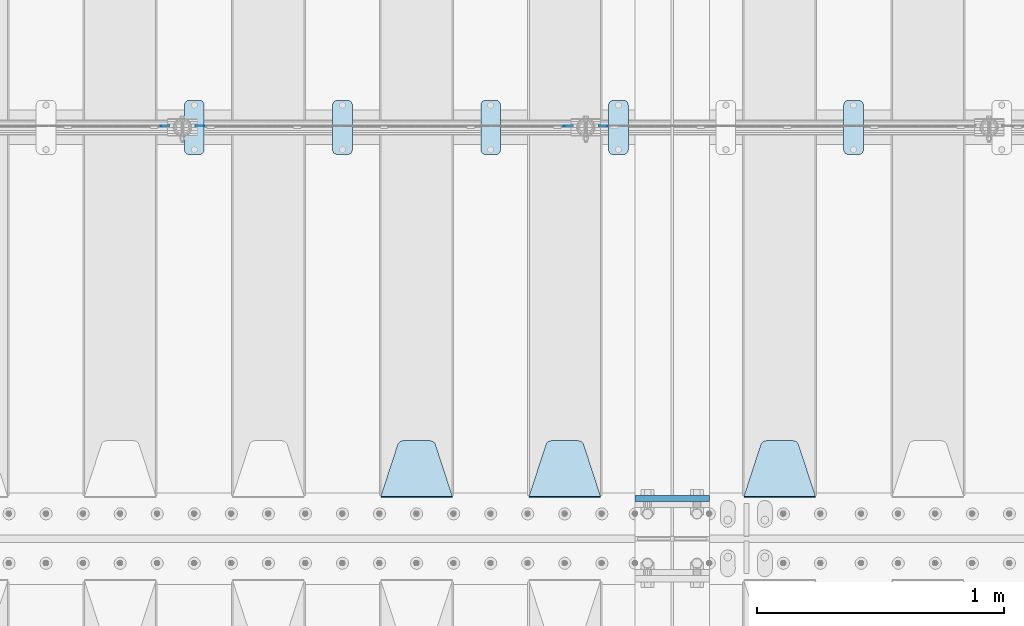
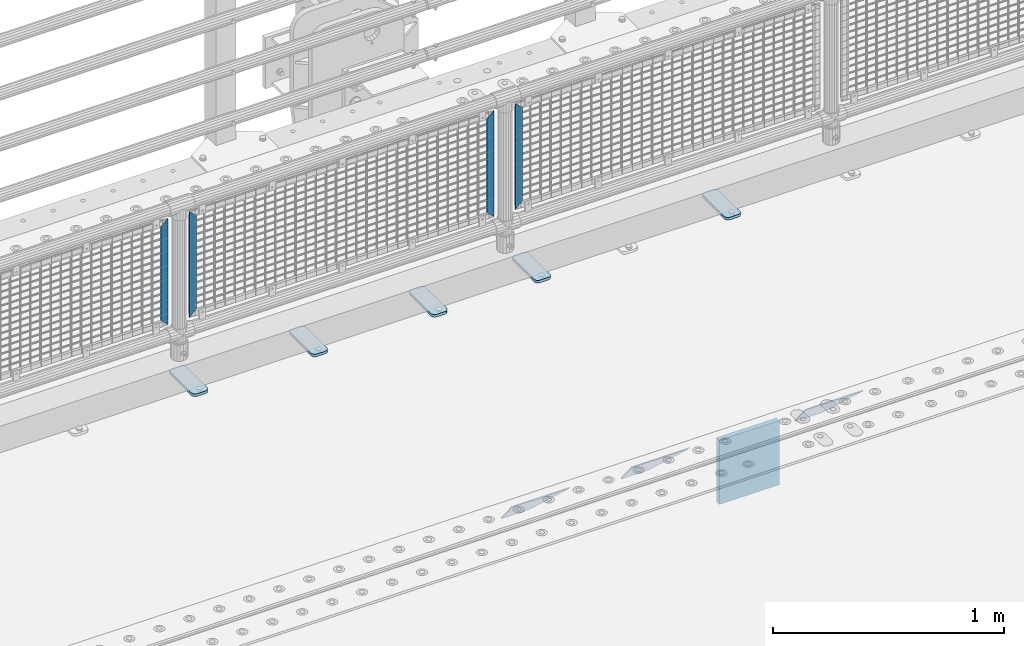
# One storey, part 214 of 242: 13 plates.
"""IFC2X3 building model written with IfcOpenShell, lengths in millimetres."""

from ifc_helpers import new_model, si_unit, frame, origin_with_axes, place, context, subcontext, project, spatial, faceted_brep, material, type_object, element, save


model = new_model("IFC2X3")

# Units and contexts
model_context = context("Model", 3, precision=1e-05, world=origin_with_axes())
body_context = subcontext(model_context, "Body", "Model", "MODEL_VIEW")
ifc_project = project(units=[si_unit("LENGTHUNIT", "METRE", prefix="MILLI"), si_unit("AREAUNIT", "SQUARE_METRE"), si_unit("VOLUMEUNIT", "CUBIC_METRE"), si_unit("MASSUNIT", "GRAM", prefix="KILO"), si_unit("TIMEUNIT", "SECOND"), si_unit("PLANEANGLEUNIT", "RADIAN"), si_unit("SOLIDANGLEUNIT", "STERADIAN"), si_unit("THERMODYNAMICTEMPERATUREUNIT", "DEGREE_CELSIUS"), si_unit("LUMINOUSINTENSITYUNIT", "LUMEN")], contexts=[model_context])

# Site, building, storey
site_placement = place(None, origin_with_axes())
site = spatial("IfcSite", under=ifc_project, at=site_placement, CompositionType="ELEMENT")
building_placement = place(site_placement, origin_with_axes())
building = spatial("IfcBuilding", under=site, at=building_placement, Name="Standard", CompositionType="ELEMENT")
storey_placement = place(building_placement, origin_with_axes())
storey = spatial("IfcBuildingStorey", under=building, at=storey_placement, Name="Undefined", CompositionType="ELEMENT", Elevation=0.0)

# Plates
ifc_material_1 = material(Name="Misc_Undefined")
plate_type_1 = type_object("IfcPlateType", PredefinedType="NOTDEFINED")
for number, where, z_axis, x_axis in (
    (1, (-28676.490286459, -19329.5, 879.519963133601), (-0.707008801899319, 0.0, -0.707204746899291), (-0.707204746899296, 0.0, 0.707008801899313)),
    (2, (-30309.490286459, -19329.5, 879.519963133601), (-0.707008801899319, 0.0, -0.707204746899291), (-0.707204746899296, 0.0, 0.707008801899313)),
):
    element("IfcPlate", number, at=place(storey_placement, frame(where, z_axis=z_axis, x_axis=x_axis)), inside=storey, type_object=plate_type_1, material=ifc_material_1, context=body_context, shape_type="Brep", body=[
        faceted_brep([(0.0, -1.50000000000364, 0.0), (-348.552185058597, -1.5, 348.655029296875), (-348.552185058597, 1.5, 348.655029296875), (-3.63797880709171e-12, 1.49999999999636, 0.0), (-348.544891357426, -1.5, 398.152496337891), (-348.544891357426, 1.5, 398.152496337891), (49.5043945312464, -1.5, 8.00355337560177e-11), (49.5043945312464, 1.5, 8.00355337560177e-11)], [[[0, 1, 2, 3]], [[1, 4, 5, 2]], [[4, 6, 7, 5]], [[6, 0, 3, 7]], [[5, 7, 3, 2]], [[6, 4, 1, 0]]]),
    ])
for number, where, z_axis, x_axis in (
    (3, (-28853.5003125164, -19329.5, 879.52), (0.707103624179499, 0.0, -0.707109938179501), (0.707109938179508, 0.0, 0.707103624179492)),
    (4, (-30486.5003125164, -19329.5, 879.52), (0.707103624179499, 0.0, -0.707109938179501), (0.707109938179508, 0.0, 0.707103624179492)),
):
    element("IfcPlate", number, at=place(storey_placement, frame(where, z_axis=z_axis, x_axis=x_axis)), inside=storey, type_object=plate_type_1, material=ifc_material_1, context=body_context, shape_type="Brep", body=[
        faceted_brep([(0.0, -1.50000000000364, 0.0), (-348.605163574222, -1.5, 348.602081298832), (-348.605163574222, 1.5, 348.602081298832), (-3.63797880709171e-12, 1.49999999999636, 0.0), (-348.605163574222, -1.5, 398.099334716801), (-348.605163574222, 1.5, 398.099334716801), (49.4976959228534, -1.5, -3.63797880709171e-12), (49.4976959228534, 1.5, -3.63797880709171e-12)], [[[0, 1, 2, 3]], [[1, 4, 5, 2]], [[4, 6, 7, 5]], [[6, 0, 3, 7]], [[5, 7, 3, 2]], [[6, 4, 1, 0]]]),
    ])
ifc_material_2 = material(Name="STEEL/S355J2")
plate_type_2 = type_object("IfcPlateType", PredefinedType="NOTDEFINED")
plate_1_placement = place(storey_placement, frame((-27721.0, -19225.5, 21.0199999999977), z_axis=(1.0, 0.0, 0.0), x_axis=(0.0, -1.0, 0.0)))
element("IfcPlate", 5, at=plate_1_placement, inside=storey, type_object=plate_type_2, material=ifc_material_2, context=body_context, shape_type="Brep", body=[
    faceted_brep([(0.0, -7.0, 20.0), (0.0, -7.0, 60.0), (0.0, 7.0, 60.0), (0.0, 7.0, 20.0), (0.384294391937146, -7.0, 63.9018064403208), (0.384294391937146, 7.0, 63.9018064403208), (1.52240934977453, -7.0, 67.6536686473009), (1.52240934977453, 7.0, 67.6536686473009), (3.37060775395003, -7.0, 71.1114046603907), (3.37060775395003, 7.0, 71.1114046603907), (5.8578643762703, -7.0, 74.1421356237297), (5.8578643762703, 7.0, 74.1421356237297), (8.88859533960931, -7.0, 76.62939224605), (8.88859533960931, 7.0, 76.62939224605), (12.3463313526991, -7.0, 78.4775906502255), (12.3463313526991, 7.0, 78.4775906502255), (16.0981935596792, -7.0, 79.6157056080629), (16.0981935596792, 7.0, 79.6157056080629), (20.0, -7.0, 80.0), (20.0, 7.0, 80.0), (200.0, -7.0, 80.0), (200.0, 7.0, 80.0), (203.901806440321, -7.0, 79.6157056080629), (203.901806440321, 7.0, 79.6157056080629), (207.653668647301, -7.0, 78.4775906502255), (207.653668647301, 7.0, 78.4775906502255), (211.111404660391, -7.0, 76.62939224605), (211.111404660391, 7.0, 76.62939224605), (214.14213562373, -7.0, 74.1421356237297), (214.14213562373, 7.0, 74.1421356237297), (216.62939224605, -7.0, 71.1114046603907), (216.62939224605, 7.0, 71.1114046603907), (218.477590650225, -7.0, 67.6536686473009), (218.477590650225, 7.0, 67.6536686473009), (219.615705608063, -7.0, 63.9018064403208), (219.615705608063, 7.0, 63.9018064403208), (220.0, -7.0, 60.0), (220.0, 7.0, 60.0), (220.0, -7.0, 20.0), (220.0, 7.0, 20.0), (219.615705608063, -7.0, 16.0981935596792), (219.615705608063, 7.0, 16.0981935596792), (218.477590650225, -7.0, 12.3463313526991), (218.477590650225, 7.0, 12.3463313526991), (216.62939224605, -7.0, 8.88859533960931), (216.62939224605, 7.0, 8.88859533960931), (214.14213562373, -7.0, 5.8578643762703), (214.14213562373, 7.0, 5.8578643762703), (211.111404660391, -7.0, 3.37060775395003), (211.111404660391, 7.0, 3.37060775395003), (207.653668647301, -7.0, 1.52240934977453), (207.653668647301, 7.0, 1.52240934977453), (203.901806440321, -7.0, 0.384294391937146), (203.901806440321, 7.0, 0.384294391937146), (200.0, -7.0, 0.0), (200.0, 7.0, 0.0), (20.0, -7.0, 0.0), (20.0, 7.0, 0.0), (16.0981935596792, -7.0, 0.384294391937146), (16.0981935596792, 7.0, 0.384294391937146), (12.3463313526991, -7.0, 1.52240934977453), (12.3463313526991, 7.0, 1.52240934977453), (8.88859533960931, -7.0, 3.37060775395003), (8.88859533960931, 7.0, 3.37060775395003), (5.8578643762703, -7.0, 5.8578643762703), (5.8578643762703, 7.0, 5.8578643762703), (3.37060775395003, -7.0, 8.88859533960931), (3.37060775395003, 7.0, 8.88859533960931), (1.52240934977453, -7.0, 12.3463313526991), (1.52240934977453, 7.0, 12.3463313526991), (0.384294391937146, -7.0, 16.0981935596792), (0.384294391937146, 7.0, 16.0981935596792)], [[[0, 1, 2, 3]], [[1, 4, 5, 2]], [[4, 6, 7, 5]], [[6, 8, 9, 7]], [[8, 10, 11, 9]], [[10, 12, 13, 11]], [[12, 14, 15, 13]], [[14, 16, 17, 15]], [[16, 18, 19, 17]], [[18, 20, 21, 19]], [[20, 22, 23, 21]], [[22, 24, 25, 23]], [[24, 26, 27, 25]], [[26, 28, 29, 27]], [[28, 30, 31, 29]], [[30, 32, 33, 31]], [[32, 34, 35, 33]], [[34, 36, 37, 35]], [[36, 38, 39, 37]], [[38, 40, 41, 39]], [[40, 42, 43, 41]], [[42, 44, 45, 43]], [[44, 46, 47, 45]], [[46, 48, 49, 47]], [[48, 50, 51, 49]], [[50, 52, 53, 51]], [[52, 54, 55, 53]], [[54, 56, 57, 55]], [[56, 58, 59, 57]], [[58, 60, 61, 59]], [[60, 62, 63, 61]], [[62, 64, 65, 63]], [[64, 66, 67, 65]], [[66, 68, 69, 67]], [[68, 70, 71, 69]], [[70, 0, 3, 71]], [[5, 7, 9, 11, 13, 15, 17, 19, 21, 23, 25, 27, 29, 31, 33, 35, 37, 39, 41, 43, 45, 47, 49, 51, 53, 55, 57, 59, 61, 63, 65, 67, 69, 71, 3, 2]], [[70, 68, 66, 64, 62, 60, 58, 56, 54, 52, 50, 48, 46, 44, 42, 40, 38, 36, 34, 32, 30, 28, 26, 24, 22, 20, 18, 16, 14, 12, 10, 8, 6, 4, 1, 0]]]),
])
plate_2_placement = place(storey_placement, frame((-28673.0, -19225.5, 21.0199999999977), z_axis=(1.0, 0.0, 0.0), x_axis=(0.0, -1.0, 0.0)))
element("IfcPlate", 6, at=plate_2_placement, inside=storey, type_object=plate_type_2, material=ifc_material_2, context=body_context, shape_type="Brep", body=[
    faceted_brep([(0.0, -7.0, 20.0), (0.0, -7.0, 60.0), (0.0, 7.0, 60.0), (0.0, 7.0, 20.0), (0.384294391937146, -7.0, 63.9018064403208), (0.384294391937146, 7.0, 63.9018064403208), (1.52240934977453, -7.0, 67.6536686473009), (1.52240934977453, 7.0, 67.6536686473009), (3.37060775395003, -7.0, 71.1114046603907), (3.37060775395003, 7.0, 71.1114046603907), (5.8578643762703, -7.0, 74.1421356237297), (5.8578643762703, 7.0, 74.1421356237297), (8.88859533960931, -7.0, 76.62939224605), (8.88859533960931, 7.0, 76.62939224605), (12.3463313526991, -7.0, 78.4775906502255), (12.3463313526991, 7.0, 78.4775906502255), (16.0981935596792, -7.0, 79.6157056080629), (16.0981935596792, 7.0, 79.6157056080629), (20.0, -7.0, 80.0), (20.0, 7.0, 80.0), (200.0, -7.0, 80.0), (200.0, 7.0, 80.0), (203.901806440321, -7.0, 79.6157056080629), (203.901806440321, 7.0, 79.6157056080629), (207.653668647301, -7.0, 78.4775906502255), (207.653668647301, 7.0, 78.4775906502255), (211.111404660391, -7.0, 76.62939224605), (211.111404660391, 7.0, 76.62939224605), (214.14213562373, -7.0, 74.1421356237297), (214.14213562373, 7.0, 74.1421356237297), (216.62939224605, -7.0, 71.1114046603907), (216.62939224605, 7.0, 71.1114046603907), (218.477590650225, -7.0, 67.6536686473009), (218.477590650225, 7.0, 67.6536686473009), (219.615705608063, -7.0, 63.9018064403208), (219.615705608063, 7.0, 63.9018064403208), (220.0, -7.0, 60.0), (220.0, 7.0, 60.0), (220.0, -7.0, 20.0), (220.0, 7.0, 20.0), (219.615705608063, -7.0, 16.0981935596792), (219.615705608063, 7.0, 16.0981935596792), (218.477590650225, -7.0, 12.3463313526991), (218.477590650225, 7.0, 12.3463313526991), (216.62939224605, -7.0, 8.88859533960931), (216.62939224605, 7.0, 8.88859533960931), (214.14213562373, -7.0, 5.8578643762703), (214.14213562373, 7.0, 5.8578643762703), (211.111404660391, -7.0, 3.37060775395003), (211.111404660391, 7.0, 3.37060775395003), (207.653668647301, -7.0, 1.52240934977453), (207.653668647301, 7.0, 1.52240934977453), (203.901806440321, -7.0, 0.384294391937146), (203.901806440321, 7.0, 0.384294391937146), (200.0, -7.0, 0.0), (200.0, 7.0, 0.0), (20.0, -7.0, 0.0), (20.0, 7.0, 0.0), (16.0981935596792, -7.0, 0.384294391937146), (16.0981935596792, 7.0, 0.384294391937146), (12.3463313526991, -7.0, 1.52240934977453), (12.3463313526991, 7.0, 1.52240934977453), (8.88859533960931, -7.0, 3.37060775395003), (8.88859533960931, 7.0, 3.37060775395003), (5.8578643762703, -7.0, 5.8578643762703), (5.8578643762703, 7.0, 5.8578643762703), (3.37060775395003, -7.0, 8.88859533960931), (3.37060775395003, 7.0, 8.88859533960931), (1.52240934977453, -7.0, 12.3463313526991), (1.52240934977453, 7.0, 12.3463313526991), (0.384294391937146, -7.0, 16.0981935596792), (0.384294391937146, 7.0, 16.0981935596792)], [[[0, 1, 2, 3]], [[1, 4, 5, 2]], [[4, 6, 7, 5]], [[6, 8, 9, 7]], [[8, 10, 11, 9]], [[10, 12, 13, 11]], [[12, 14, 15, 13]], [[14, 16, 17, 15]], [[16, 18, 19, 17]], [[18, 20, 21, 19]], [[20, 22, 23, 21]], [[22, 24, 25, 23]], [[24, 26, 27, 25]], [[26, 28, 29, 27]], [[28, 30, 31, 29]], [[30, 32, 33, 31]], [[32, 34, 35, 33]], [[34, 36, 37, 35]], [[36, 38, 39, 37]], [[38, 40, 41, 39]], [[40, 42, 43, 41]], [[42, 44, 45, 43]], [[44, 46, 47, 45]], [[46, 48, 49, 47]], [[48, 50, 51, 49]], [[50, 52, 53, 51]], [[52, 54, 55, 53]], [[54, 56, 57, 55]], [[56, 58, 59, 57]], [[58, 60, 61, 59]], [[60, 62, 63, 61]], [[62, 64, 65, 63]], [[64, 66, 67, 65]], [[66, 68, 69, 67]], [[68, 70, 71, 69]], [[70, 0, 3, 71]], [[5, 7, 9, 11, 13, 15, 17, 19, 21, 23, 25, 27, 29, 31, 33, 35, 37, 39, 41, 43, 45, 47, 49, 51, 53, 55, 57, 59, 61, 63, 65, 67, 69, 71, 3, 2]], [[70, 68, 66, 64, 62, 60, 58, 56, 54, 52, 50, 48, 46, 44, 42, 40, 38, 36, 34, 32, 30, 28, 26, 24, 22, 20, 18, 16, 14, 12, 10, 8, 6, 4, 1, 0]]]),
])
plate_3_placement = place(storey_placement, frame((-29190.0, -19225.5, 21.0199999999977), z_axis=(1.0, 0.0, 0.0), x_axis=(0.0, -1.0, 0.0)))
element("IfcPlate", 7, at=plate_3_placement, inside=storey, type_object=plate_type_2, material=ifc_material_2, context=body_context, shape_type="Brep", body=[
    faceted_brep([(0.0, -7.0, 20.0), (0.0, -7.0, 60.0), (0.0, 7.0, 60.0), (0.0, 7.0, 20.0), (0.384294391937146, -7.0, 63.9018064403208), (0.384294391937146, 7.0, 63.9018064403208), (1.52240934977453, -7.0, 67.6536686473009), (1.52240934977453, 7.0, 67.6536686473009), (3.37060775395003, -7.0, 71.1114046603907), (3.37060775395003, 7.0, 71.1114046603907), (5.8578643762703, -7.0, 74.1421356237297), (5.8578643762703, 7.0, 74.1421356237297), (8.88859533960931, -7.0, 76.62939224605), (8.88859533960931, 7.0, 76.62939224605), (12.3463313526991, -7.0, 78.4775906502255), (12.3463313526991, 7.0, 78.4775906502255), (16.0981935596792, -7.0, 79.6157056080629), (16.0981935596792, 7.0, 79.6157056080629), (20.0, -7.0, 80.0), (20.0, 7.0, 80.0), (200.0, -7.0, 80.0), (200.0, 7.0, 80.0), (203.901806440321, -7.0, 79.6157056080629), (203.901806440321, 7.0, 79.6157056080629), (207.653668647301, -7.0, 78.4775906502255), (207.653668647301, 7.0, 78.4775906502255), (211.111404660391, -7.0, 76.62939224605), (211.111404660391, 7.0, 76.62939224605), (214.14213562373, -7.0, 74.1421356237297), (214.14213562373, 7.0, 74.1421356237297), (216.62939224605, -7.0, 71.1114046603907), (216.62939224605, 7.0, 71.1114046603907), (218.477590650225, -7.0, 67.6536686473009), (218.477590650225, 7.0, 67.6536686473009), (219.615705608063, -7.0, 63.9018064403208), (219.615705608063, 7.0, 63.9018064403208), (220.0, -7.0, 60.0), (220.0, 7.0, 60.0), (220.0, -7.0, 20.0), (220.0, 7.0, 20.0), (219.615705608063, -7.0, 16.0981935596792), (219.615705608063, 7.0, 16.0981935596792), (218.477590650225, -7.0, 12.3463313526991), (218.477590650225, 7.0, 12.3463313526991), (216.62939224605, -7.0, 8.88859533960931), (216.62939224605, 7.0, 8.88859533960931), (214.14213562373, -7.0, 5.8578643762703), (214.14213562373, 7.0, 5.8578643762703), (211.111404660391, -7.0, 3.37060775395003), (211.111404660391, 7.0, 3.37060775395003), (207.653668647301, -7.0, 1.52240934977453), (207.653668647301, 7.0, 1.52240934977453), (203.901806440321, -7.0, 0.384294391937146), (203.901806440321, 7.0, 0.384294391937146), (200.0, -7.0, 0.0), (200.0, 7.0, 0.0), (20.0, -7.0, 0.0), (20.0, 7.0, 0.0), (16.0981935596792, -7.0, 0.384294391937146), (16.0981935596792, 7.0, 0.384294391937146), (12.3463313526991, -7.0, 1.52240934977453), (12.3463313526991, 7.0, 1.52240934977453), (8.88859533960931, -7.0, 3.37060775395003), (8.88859533960931, 7.0, 3.37060775395003), (5.8578643762703, -7.0, 5.8578643762703), (5.8578643762703, 7.0, 5.8578643762703), (3.37060775395003, -7.0, 8.88859533960931), (3.37060775395003, 7.0, 8.88859533960931), (1.52240934977453, -7.0, 12.3463313526991), (1.52240934977453, 7.0, 12.3463313526991), (0.384294391937146, -7.0, 16.0981935596792), (0.384294391937146, 7.0, 16.0981935596792)], [[[0, 1, 2, 3]], [[1, 4, 5, 2]], [[4, 6, 7, 5]], [[6, 8, 9, 7]], [[8, 10, 11, 9]], [[10, 12, 13, 11]], [[12, 14, 15, 13]], [[14, 16, 17, 15]], [[16, 18, 19, 17]], [[18, 20, 21, 19]], [[20, 22, 23, 21]], [[22, 24, 25, 23]], [[24, 26, 27, 25]], [[26, 28, 29, 27]], [[28, 30, 31, 29]], [[30, 32, 33, 31]], [[32, 34, 35, 33]], [[34, 36, 37, 35]], [[36, 38, 39, 37]], [[38, 40, 41, 39]], [[40, 42, 43, 41]], [[42, 44, 45, 43]], [[44, 46, 47, 45]], [[46, 48, 49, 47]], [[48, 50, 51, 49]], [[50, 52, 53, 51]], [[52, 54, 55, 53]], [[54, 56, 57, 55]], [[56, 58, 59, 57]], [[58, 60, 61, 59]], [[60, 62, 63, 61]], [[62, 64, 65, 63]], [[64, 66, 67, 65]], [[66, 68, 69, 67]], [[68, 70, 71, 69]], [[70, 0, 3, 71]], [[5, 7, 9, 11, 13, 15, 17, 19, 21, 23, 25, 27, 29, 31, 33, 35, 37, 39, 41, 43, 45, 47, 49, 51, 53, 55, 57, 59, 61, 63, 65, 67, 69, 71, 3, 2]], [[70, 68, 66, 64, 62, 60, 58, 56, 54, 52, 50, 48, 46, 44, 42, 40, 38, 36, 34, 32, 30, 28, 26, 24, 22, 20, 18, 16, 14, 12, 10, 8, 6, 4, 1, 0]]]),
])
plate_4_placement = place(storey_placement, frame((-29790.0, -19225.5, 21.0199999999977), z_axis=(1.0, 0.0, 0.0), x_axis=(0.0, -1.0, 0.0)))
element("IfcPlate", 8, at=plate_4_placement, inside=storey, type_object=plate_type_2, material=ifc_material_2, context=body_context, shape_type="Brep", body=[
    faceted_brep([(0.0, -7.0, 20.0), (0.0, -7.0, 60.0), (0.0, 7.0, 60.0), (0.0, 7.0, 20.0), (0.384294391937146, -7.0, 63.9018064403208), (0.384294391937146, 7.0, 63.9018064403208), (1.52240934977453, -7.0, 67.6536686473009), (1.52240934977453, 7.0, 67.6536686473009), (3.37060775395003, -7.0, 71.1114046603907), (3.37060775395003, 7.0, 71.1114046603907), (5.8578643762703, -7.0, 74.1421356237297), (5.8578643762703, 7.0, 74.1421356237297), (8.88859533960931, -7.0, 76.62939224605), (8.88859533960931, 7.0, 76.62939224605), (12.3463313526991, -7.0, 78.4775906502255), (12.3463313526991, 7.0, 78.4775906502255), (16.0981935596792, -7.0, 79.6157056080629), (16.0981935596792, 7.0, 79.6157056080629), (20.0, -7.0, 80.0), (20.0, 7.0, 80.0), (200.0, -7.0, 80.0), (200.0, 7.0, 80.0), (203.901806440321, -7.0, 79.6157056080629), (203.901806440321, 7.0, 79.6157056080629), (207.653668647301, -7.0, 78.4775906502255), (207.653668647301, 7.0, 78.4775906502255), (211.111404660391, -7.0, 76.62939224605), (211.111404660391, 7.0, 76.62939224605), (214.14213562373, -7.0, 74.1421356237297), (214.14213562373, 7.0, 74.1421356237297), (216.62939224605, -7.0, 71.1114046603907), (216.62939224605, 7.0, 71.1114046603907), (218.477590650225, -7.0, 67.6536686473009), (218.477590650225, 7.0, 67.6536686473009), (219.615705608063, -7.0, 63.9018064403208), (219.615705608063, 7.0, 63.9018064403208), (220.0, -7.0, 60.0), (220.0, 7.0, 60.0), (220.0, -7.0, 20.0), (220.0, 7.0, 20.0), (219.615705608063, -7.0, 16.0981935596792), (219.615705608063, 7.0, 16.0981935596792), (218.477590650225, -7.0, 12.3463313526991), (218.477590650225, 7.0, 12.3463313526991), (216.62939224605, -7.0, 8.88859533960931), (216.62939224605, 7.0, 8.88859533960931), (214.14213562373, -7.0, 5.8578643762703), (214.14213562373, 7.0, 5.8578643762703), (211.111404660391, -7.0, 3.37060775395003), (211.111404660391, 7.0, 3.37060775395003), (207.653668647301, -7.0, 1.52240934977453), (207.653668647301, 7.0, 1.52240934977453), (203.901806440321, -7.0, 0.384294391937146), (203.901806440321, 7.0, 0.384294391937146), (200.0, -7.0, 0.0), (200.0, 7.0, 0.0), (20.0, -7.0, 0.0), (20.0, 7.0, 0.0), (16.0981935596792, -7.0, 0.384294391937146), (16.0981935596792, 7.0, 0.384294391937146), (12.3463313526991, -7.0, 1.52240934977453), (12.3463313526991, 7.0, 1.52240934977453), (8.88859533960931, -7.0, 3.37060775395003), (8.88859533960931, 7.0, 3.37060775395003), (5.8578643762703, -7.0, 5.8578643762703), (5.8578643762703, 7.0, 5.8578643762703), (3.37060775395003, -7.0, 8.88859533960931), (3.37060775395003, 7.0, 8.88859533960931), (1.52240934977453, -7.0, 12.3463313526991), (1.52240934977453, 7.0, 12.3463313526991), (0.384294391937146, -7.0, 16.0981935596792), (0.384294391937146, 7.0, 16.0981935596792)], [[[0, 1, 2, 3]], [[1, 4, 5, 2]], [[4, 6, 7, 5]], [[6, 8, 9, 7]], [[8, 10, 11, 9]], [[10, 12, 13, 11]], [[12, 14, 15, 13]], [[14, 16, 17, 15]], [[16, 18, 19, 17]], [[18, 20, 21, 19]], [[20, 22, 23, 21]], [[22, 24, 25, 23]], [[24, 26, 27, 25]], [[26, 28, 29, 27]], [[28, 30, 31, 29]], [[30, 32, 33, 31]], [[32, 34, 35, 33]], [[34, 36, 37, 35]], [[36, 38, 39, 37]], [[38, 40, 41, 39]], [[40, 42, 43, 41]], [[42, 44, 45, 43]], [[44, 46, 47, 45]], [[46, 48, 49, 47]], [[48, 50, 51, 49]], [[50, 52, 53, 51]], [[52, 54, 55, 53]], [[54, 56, 57, 55]], [[56, 58, 59, 57]], [[58, 60, 61, 59]], [[60, 62, 63, 61]], [[62, 64, 65, 63]], [[64, 66, 67, 65]], [[66, 68, 69, 67]], [[68, 70, 71, 69]], [[70, 0, 3, 71]], [[5, 7, 9, 11, 13, 15, 17, 19, 21, 23, 25, 27, 29, 31, 33, 35, 37, 39, 41, 43, 45, 47, 49, 51, 53, 55, 57, 59, 61, 63, 65, 67, 69, 71, 3, 2]], [[70, 68, 66, 64, 62, 60, 58, 56, 54, 52, 50, 48, 46, 44, 42, 40, 38, 36, 34, 32, 30, 28, 26, 24, 22, 20, 18, 16, 14, 12, 10, 8, 6, 4, 1, 0]]]),
])
plate_5_placement = place(storey_placement, frame((-30390.0, -19225.5, 21.0199999999977), z_axis=(1.0, 0.0, 0.0), x_axis=(0.0, -1.0, 0.0)))
element("IfcPlate", 9, at=plate_5_placement, inside=storey, type_object=plate_type_2, material=ifc_material_2, context=body_context, shape_type="Brep", body=[
    faceted_brep([(0.0, -7.0, 20.0), (0.0, -7.0, 60.0), (0.0, 7.0, 60.0), (0.0, 7.0, 20.0), (0.384294391937146, -7.0, 63.9018064403208), (0.384294391937146, 7.0, 63.9018064403208), (1.52240934977453, -7.0, 67.6536686473009), (1.52240934977453, 7.0, 67.6536686473009), (3.37060775395003, -7.0, 71.1114046603907), (3.37060775395003, 7.0, 71.1114046603907), (5.8578643762703, -7.0, 74.1421356237297), (5.8578643762703, 7.0, 74.1421356237297), (8.88859533960931, -7.0, 76.62939224605), (8.88859533960931, 7.0, 76.62939224605), (12.3463313526991, -7.0, 78.4775906502255), (12.3463313526991, 7.0, 78.4775906502255), (16.0981935596792, -7.0, 79.6157056080629), (16.0981935596792, 7.0, 79.6157056080629), (20.0, -7.0, 80.0), (20.0, 7.0, 80.0), (200.0, -7.0, 80.0), (200.0, 7.0, 80.0), (203.901806440321, -7.0, 79.6157056080629), (203.901806440321, 7.0, 79.6157056080629), (207.653668647301, -7.0, 78.4775906502255), (207.653668647301, 7.0, 78.4775906502255), (211.111404660391, -7.0, 76.62939224605), (211.111404660391, 7.0, 76.62939224605), (214.14213562373, -7.0, 74.1421356237297), (214.14213562373, 7.0, 74.1421356237297), (216.62939224605, -7.0, 71.1114046603907), (216.62939224605, 7.0, 71.1114046603907), (218.477590650225, -7.0, 67.6536686473009), (218.477590650225, 7.0, 67.6536686473009), (219.615705608063, -7.0, 63.9018064403208), (219.615705608063, 7.0, 63.9018064403208), (220.0, -7.0, 60.0), (220.0, 7.0, 60.0), (220.0, -7.0, 20.0), (220.0, 7.0, 20.0), (219.615705608063, -7.0, 16.0981935596792), (219.615705608063, 7.0, 16.0981935596792), (218.477590650225, -7.0, 12.3463313526991), (218.477590650225, 7.0, 12.3463313526991), (216.62939224605, -7.0, 8.88859533960931), (216.62939224605, 7.0, 8.88859533960931), (214.14213562373, -7.0, 5.8578643762703), (214.14213562373, 7.0, 5.8578643762703), (211.111404660391, -7.0, 3.37060775395003), (211.111404660391, 7.0, 3.37060775395003), (207.653668647301, -7.0, 1.52240934977453), (207.653668647301, 7.0, 1.52240934977453), (203.901806440321, -7.0, 0.384294391937146), (203.901806440321, 7.0, 0.384294391937146), (200.0, -7.0, 0.0), (200.0, 7.0, 0.0), (20.0, -7.0, 0.0), (20.0, 7.0, 0.0), (16.0981935596792, -7.0, 0.384294391937146), (16.0981935596792, 7.0, 0.384294391937146), (12.3463313526991, -7.0, 1.52240934977453), (12.3463313526991, 7.0, 1.52240934977453), (8.88859533960931, -7.0, 3.37060775395003), (8.88859533960931, 7.0, 3.37060775395003), (5.8578643762703, -7.0, 5.8578643762703), (5.8578643762703, 7.0, 5.8578643762703), (3.37060775395003, -7.0, 8.88859533960931), (3.37060775395003, 7.0, 8.88859533960931), (1.52240934977453, -7.0, 12.3463313526991), (1.52240934977453, 7.0, 12.3463313526991), (0.384294391937146, -7.0, 16.0981935596792), (0.384294391937146, 7.0, 16.0981935596792)], [[[0, 1, 2, 3]], [[1, 4, 5, 2]], [[4, 6, 7, 5]], [[6, 8, 9, 7]], [[8, 10, 11, 9]], [[10, 12, 13, 11]], [[12, 14, 15, 13]], [[14, 16, 17, 15]], [[16, 18, 19, 17]], [[18, 20, 21, 19]], [[20, 22, 23, 21]], [[22, 24, 25, 23]], [[24, 26, 27, 25]], [[26, 28, 29, 27]], [[28, 30, 31, 29]], [[30, 32, 33, 31]], [[32, 34, 35, 33]], [[34, 36, 37, 35]], [[36, 38, 39, 37]], [[38, 40, 41, 39]], [[40, 42, 43, 41]], [[42, 44, 45, 43]], [[44, 46, 47, 45]], [[46, 48, 49, 47]], [[48, 50, 51, 49]], [[50, 52, 53, 51]], [[52, 54, 55, 53]], [[54, 56, 57, 55]], [[56, 58, 59, 57]], [[58, 60, 61, 59]], [[60, 62, 63, 61]], [[62, 64, 65, 63]], [[64, 66, 67, 65]], [[66, 68, 69, 67]], [[68, 70, 71, 69]], [[70, 0, 3, 71]], [[5, 7, 9, 11, 13, 15, 17, 19, 21, 23, 25, 27, 29, 31, 33, 35, 37, 39, 41, 43, 45, 47, 49, 51, 53, 55, 57, 59, 61, 63, 65, 67, 69, 71, 3, 2]], [[70, 68, 66, 64, 62, 60, 58, 56, 54, 52, 50, 48, 46, 44, 42, 40, 38, 36, 34, 32, 30, 28, 26, 24, 22, 20, 18, 16, 14, 12, 10, 8, 6, 4, 1, 0]]]),
])
ifc_material_3 = material(Name="STEEL/S355N")
plate_type_3 = type_object("IfcPlateType", PredefinedType="NOTDEFINED")
plate_6_placement = place(storey_placement, frame((-28565.0, -20837.5, -340.000000000044), z_axis=(0.0, 0.0, 1.0), x_axis=(1.0, 0.0, 0.0)))
element("IfcPlate", 10, at=plate_6_placement, inside=storey, type_object=plate_type_3, material=ifc_material_3, context=body_context, shape_type="Brep", body=[
    faceted_brep([(0.0, -12.5, 0.0), (9.27684595808387e-10, -12.5, 340.0), (9.27684595808387e-10, 12.5, 340.0), (0.0, 12.5, 0.0), (300.0, -12.5, 340.0), (300.0, 12.5, 340.0), (300.0, -12.5, 0.0), (300.0, 12.5, 0.0)], [[[0, 1, 2, 3]], [[1, 4, 5, 2]], [[4, 6, 7, 5]], [[6, 0, 3, 7]], [[5, 7, 3, 2]], [[6, 4, 1, 0]]]),
])
plate_type_4 = type_object("IfcPlateType", PredefinedType="NOTDEFINED")
plate_7_placement = place(storey_placement, frame((-27835.0, -20831.767766953, -1.76776695296758), z_axis=(0.0, 0.707106781186547, -0.707106781186548), x_axis=(-1.0, 0.0, 0.0)))
element("IfcPlate", 11, at=plate_7_placement, inside=storey, type_object=plate_type_4, material=ifc_material_3, context=body_context, shape_type="Brep", body=[
    faceted_brep([(0.0, -2.5, 0.0), (69.345504679477, -2.50000000000182, 300.171731424829), (69.345504679477, 2.5, 300.171731424829), (0.0, 2.5, 0.0), (70.9274061199576, -2.5, 304.897442415398), (70.9274061199576, 2.5, 304.897442415398), (73.3818627772307, -2.5, 309.234538108525), (73.3818627772307, 2.50000000000182, 309.234538108529), (76.6187032999551, -2.5, 313.023683126101), (76.6187032999551, 2.50000000000182, 313.023683126103), (80.5190132704993, -2.5, 316.12567259537), (80.5190132704993, 2.5, 316.12567259537), (84.9395038596849, -2.5, 318.426546230474), (84.9395038596849, 2.50000000000182, 318.426546230476), (89.7177759439219, -2.49999999999818, 319.841774983273), (89.7177759439219, 2.50000000000182, 319.841774983273), (94.678286292652, -2.5, 320.319366455076), (94.678286292652, 2.5, 320.319366455076), (195.321713707348, -2.5, 320.319366455076), (195.321713707348, 2.5, 320.319366455076), (200.282224056078, -2.5, 319.841774983272), (200.282224056078, 2.50000000000182, 319.841774983273), (205.060496140315, -2.5, 318.426546230474), (205.060496140315, 2.49999999999818, 318.426546230474), (209.480986729501, -2.49999999999818, 316.12567259537), (209.480986729501, 2.5, 316.12567259537), (213.381296700045, -2.5, 313.023683126101), (213.381296700045, 2.49999999999818, 313.023683126101), (216.618137222769, -2.5, 309.234538108525), (216.618137222769, 2.5, 309.234538108523), (219.072593880042, -2.49999999999818, 304.897442415398), (219.072593880042, 2.50000000000182, 304.897442415398), (220.654495320523, -2.50000000000182, 300.171731424829), (220.654495320523, 2.5, 300.171731424829), (290.0, -2.5, 0.0), (290.0, 2.5, -1.81898940354586e-12)], [[[0, 1, 2, 3]], [[1, 4, 5, 2]], [[4, 6, 7, 5]], [[6, 8, 9, 7]], [[8, 10, 11, 9]], [[10, 12, 13, 11]], [[12, 14, 15, 13]], [[14, 16, 17, 15]], [[16, 18, 19, 17]], [[18, 20, 21, 19]], [[20, 22, 23, 21]], [[22, 24, 25, 23]], [[24, 26, 27, 25]], [[26, 28, 29, 27]], [[28, 30, 31, 29]], [[30, 32, 33, 31]], [[32, 34, 35, 33]], [[34, 0, 3, 35]], [[5, 7, 9, 11, 13, 15, 17, 19, 21, 23, 25, 27, 29, 31, 33, 35, 3, 2]], [[34, 32, 30, 28, 26, 24, 22, 20, 18, 16, 14, 12, 10, 8, 6, 4, 1, 0]]]),
])
plate_8_placement = place(storey_placement, frame((-28705.0, -20831.767766953, -1.76776695296758), z_axis=(0.0, 0.707106781186547, -0.707106781186548), x_axis=(-1.0, 0.0, 0.0)))
element("IfcPlate", 12, at=plate_8_placement, inside=storey, type_object=plate_type_4, material=ifc_material_3, context=body_context, shape_type="Brep", body=[
    faceted_brep([(0.0, -2.5, 0.0), (69.345504679477, -2.50000000000182, 300.171731424829), (69.345504679477, 2.5, 300.171731424829), (0.0, 2.5, 0.0), (70.9274061199576, -2.5, 304.897442415398), (70.9274061199576, 2.5, 304.897442415398), (73.3818627772307, -2.5, 309.234538108525), (73.3818627772307, 2.50000000000182, 309.234538108529), (76.6187032999551, -2.5, 313.023683126101), (76.6187032999551, 2.50000000000182, 313.023683126103), (80.5190132704993, -2.5, 316.12567259537), (80.5190132704993, 2.5, 316.12567259537), (84.9395038596849, -2.5, 318.426546230474), (84.9395038596849, 2.50000000000182, 318.426546230476), (89.7177759439219, -2.49999999999818, 319.841774983273), (89.7177759439219, 2.50000000000182, 319.841774983273), (94.678286292652, -2.5, 320.319366455076), (94.678286292652, 2.5, 320.319366455076), (195.321713707348, -2.5, 320.319366455076), (195.321713707348, 2.5, 320.319366455076), (200.282224056078, -2.5, 319.841774983272), (200.282224056078, 2.50000000000182, 319.841774983273), (205.060496140315, -2.5, 318.426546230474), (205.060496140315, 2.49999999999818, 318.426546230474), (209.480986729501, -2.49999999999818, 316.12567259537), (209.480986729501, 2.5, 316.12567259537), (213.381296700045, -2.5, 313.023683126101), (213.381296700045, 2.49999999999818, 313.023683126101), (216.618137222769, -2.5, 309.234538108525), (216.618137222769, 2.5, 309.234538108523), (219.072593880042, -2.49999999999818, 304.897442415398), (219.072593880042, 2.50000000000182, 304.897442415398), (220.654495320523, -2.50000000000182, 300.171731424829), (220.654495320523, 2.5, 300.171731424829), (290.0, -2.5, 0.0), (290.0, 2.5, -1.81898940354586e-12)], [[[0, 1, 2, 3]], [[1, 4, 5, 2]], [[4, 6, 7, 5]], [[6, 8, 9, 7]], [[8, 10, 11, 9]], [[10, 12, 13, 11]], [[12, 14, 15, 13]], [[14, 16, 17, 15]], [[16, 18, 19, 17]], [[18, 20, 21, 19]], [[20, 22, 23, 21]], [[22, 24, 25, 23]], [[24, 26, 27, 25]], [[26, 28, 29, 27]], [[28, 30, 31, 29]], [[30, 32, 33, 31]], [[32, 34, 35, 33]], [[34, 0, 3, 35]], [[5, 7, 9, 11, 13, 15, 17, 19, 21, 23, 25, 27, 29, 31, 33, 35, 3, 2]], [[34, 32, 30, 28, 26, 24, 22, 20, 18, 16, 14, 12, 10, 8, 6, 4, 1, 0]]]),
])
plate_9_placement = place(storey_placement, frame((-29305.0, -20831.767766953, -1.76776695296758), z_axis=(0.0, 0.707106781186547, -0.707106781186548), x_axis=(-1.0, 0.0, 0.0)))
element("IfcPlate", 13, at=plate_9_placement, inside=storey, type_object=plate_type_4, material=ifc_material_3, context=body_context, shape_type="Brep", body=[
    faceted_brep([(0.0, -2.5, 0.0), (69.345504679477, -2.50000000000182, 300.171731424829), (69.345504679477, 2.5, 300.171731424829), (0.0, 2.5, 0.0), (70.9274061199576, -2.5, 304.897442415398), (70.9274061199576, 2.5, 304.897442415398), (73.3818627772307, -2.5, 309.234538108525), (73.3818627772307, 2.50000000000182, 309.234538108529), (76.6187032999551, -2.5, 313.023683126101), (76.6187032999551, 2.50000000000182, 313.023683126103), (80.5190132704993, -2.5, 316.12567259537), (80.5190132704993, 2.5, 316.12567259537), (84.9395038596849, -2.5, 318.426546230474), (84.9395038596849, 2.50000000000182, 318.426546230476), (89.7177759439219, -2.49999999999818, 319.841774983273), (89.7177759439219, 2.50000000000182, 319.841774983273), (94.678286292652, -2.5, 320.319366455076), (94.678286292652, 2.5, 320.319366455076), (195.321713707348, -2.5, 320.319366455076), (195.321713707348, 2.5, 320.319366455076), (200.282224056078, -2.5, 319.841774983272), (200.282224056078, 2.50000000000182, 319.841774983273), (205.060496140315, -2.5, 318.426546230474), (205.060496140315, 2.49999999999818, 318.426546230474), (209.480986729501, -2.49999999999818, 316.12567259537), (209.480986729501, 2.5, 316.12567259537), (213.381296700045, -2.5, 313.023683126101), (213.381296700045, 2.49999999999818, 313.023683126101), (216.618137222769, -2.5, 309.234538108525), (216.618137222769, 2.5, 309.234538108523), (219.072593880042, -2.49999999999818, 304.897442415398), (219.072593880042, 2.50000000000182, 304.897442415398), (220.654495320523, -2.50000000000182, 300.171731424829), (220.654495320523, 2.5, 300.171731424829), (290.0, -2.5, 0.0), (290.0, 2.5, -1.81898940354586e-12)], [[[0, 1, 2, 3]], [[1, 4, 5, 2]], [[4, 6, 7, 5]], [[6, 8, 9, 7]], [[8, 10, 11, 9]], [[10, 12, 13, 11]], [[12, 14, 15, 13]], [[14, 16, 17, 15]], [[16, 18, 19, 17]], [[18, 20, 21, 19]], [[20, 22, 23, 21]], [[22, 24, 25, 23]], [[24, 26, 27, 25]], [[26, 28, 29, 27]], [[28, 30, 31, 29]], [[30, 32, 33, 31]], [[32, 34, 35, 33]], [[34, 0, 3, 35]], [[5, 7, 9, 11, 13, 15, 17, 19, 21, 23, 25, 27, 29, 31, 33, 35, 3, 2]], [[34, 32, 30, 28, 26, 24, 22, 20, 18, 16, 14, 12, 10, 8, 6, 4, 1, 0]]]),
])

save(model, "model.ifc")
